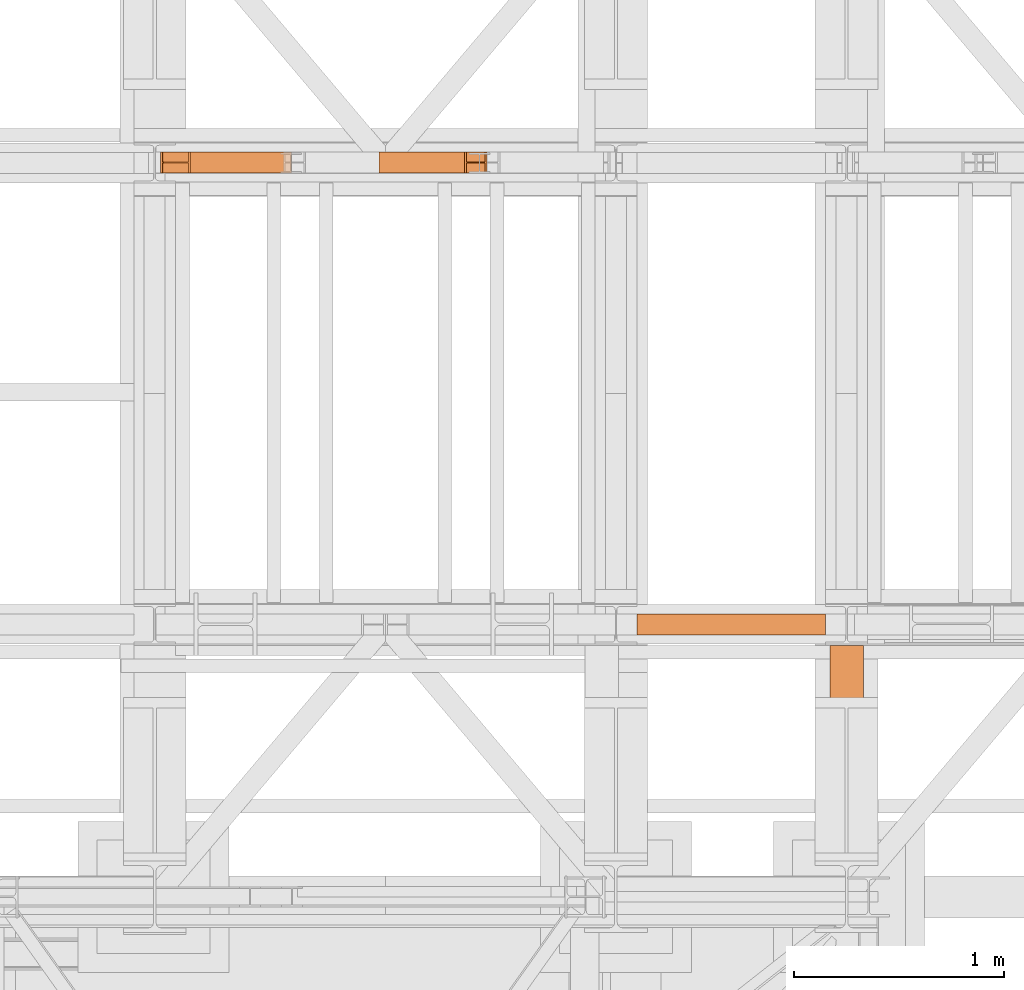
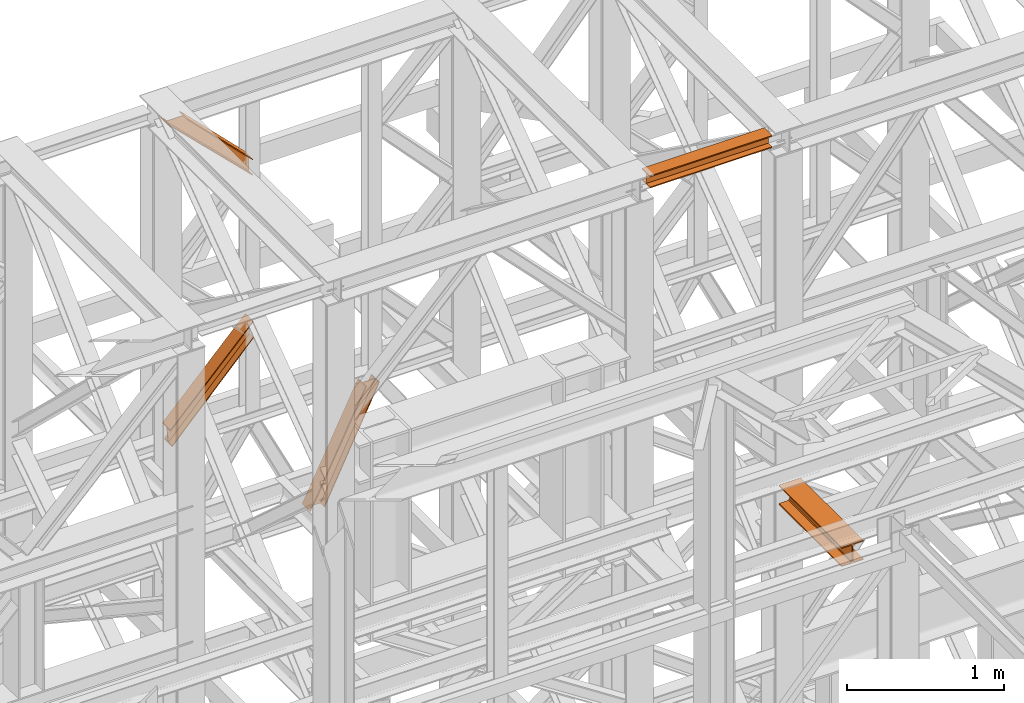
# One storey, part 204 of 208: 5 proxies.
"""IFC2X3 building model written with IfcOpenShell, lengths in millimetres."""

import ifcopenshell
import ifcopenshell.guid

model = None  # the IFC model being written
_history = None  # IfcOwnerHistory: only IFC2X3 demands one
_inside = {}  # id of a spatial element -> (the spatial element, [elements in it])
_under = {}  # id of a project, library or spatial element -> (it, [spatial elements below it])
_declared = {}  # id of a project -> (the project, [libraries it declares])
_typed = {}  # id of a type object -> (the type object, [elements of that type])
_made_of = {}  # id of a material, layer set ... -> (it, [elements and type objects made of it])


def new_model(schema):
    """Start an empty IFC model of exactly this schema.

    Asked for "IFC4X3", IfcOpenShell would pick the latest addendum, in which some entities
    have other attributes; the version numbers below select the first issue.
    IFC2X3 requires an IfcOwnerHistory on every rooted entity: one is made here for all.
    """
    global model, _history
    if schema == "IFC4X3":
        model = ifcopenshell.file(schema_version=(4, 3, 0, 0))
    else:
        model = ifcopenshell.file(schema=schema)
    _inside.clear()
    _under.clear()
    _declared.clear()
    _typed.clear()
    _made_of.clear()
    _history = None
    if model.schema == "IFC2X3":
        org = make("IfcOrganization", Name="unknown")
        user = make(
            "IfcPersonAndOrganization",
            ThePerson=make("IfcPerson", FamilyName="unknown"),
            TheOrganization=org,
        )
        app = make(
            "IfcApplication",
            ApplicationDeveloper=org,
            Version="unknown",
            ApplicationFullName="unknown",
            ApplicationIdentifier="unknown",
        )
        _history = make(
            "IfcOwnerHistory",
            OwningUser=user,
            OwningApplication=app,
            ChangeAction="ADDED",
            CreationDate=0,
        )
    return model


def make(cls, **values):
    """One entity of the class cls with the attributes given. An attribute that is None is left unset."""
    return model.create_entity(
        cls, **{name: value for name, value in values.items() if value is not None}
    )


def entity(cls, *values):
    """Any entity or typed value of the class cls, its attributes in the order of the schema. None: left unset."""
    e = model.create_entity(cls)
    for i, value in enumerate(values):
        if value is not None:
            e[i] = value
    return e


def rooted(cls, **values):
    """An entity with a GlobalId (a new one), such as an element, a storey or a relation."""
    return make(cls, GlobalId=ifcopenshell.guid.new(), OwnerHistory=_history, **values)


def si_unit(unit_type, name, prefix=None):
    """IfcSIUnit, for example si_unit("LENGTHUNIT", "METRE", prefix="MILLI")."""
    return make("IfcSIUnit", UnitType=unit_type, Prefix=prefix, Name=name)


def converted_unit(unit_type, name, factor, base, dimensions=None, offset=None):
    """IfcConversionBasedUnit, such as the inch: factor (a typed value) times the base unit."""
    return make(
        "IfcConversionBasedUnit"
        if offset is None
        else "IfcConversionBasedUnitWithOffset",
        ConversionOffset=offset,
        Dimensions=None
        if dimensions is None
        else entity("IfcDimensionalExponents", *dimensions),
        UnitType=unit_type,
        Name=name,
        ConversionFactor=make(
            "IfcMeasureWithUnit", ValueComponent=factor, UnitComponent=base
        ),
    )


def assignment(units):
    """IfcUnitAssignment: the units of a project."""
    return None if units is None else make("IfcUnitAssignment", Units=units)


def point(xyz):
    """IfcCartesianPoint."""
    return None if xyz is None else make("IfcCartesianPoint", Coordinates=xyz)


def direction(xyz):
    """IfcDirection."""
    return None if xyz is None else make("IfcDirection", DirectionRatios=xyz)


def frame(location, z_axis=None, x_axis=None):
    """IfcAxis2Placement3D, a coordinate frame: its origin and axes. An axis left out is left unset."""
    return make(
        "IfcAxis2Placement3D",
        Location=point(location),
        Axis=direction(z_axis),
        RefDirection=direction(x_axis),
    )


def origin():
    """The frame at (0, 0, 0) with its axes left unset."""
    return frame((0.0, 0.0, 0.0))


def origin_with_axes():
    """The frame at (0, 0, 0) with the z axis (0, 0, 1) and the x axis (1, 0, 0) written out."""
    return frame((0.0, 0.0, 0.0), z_axis=(0.0, 0.0, 1.0), x_axis=(1.0, 0.0, 0.0))


def place(relative_to, where):
    """IfcLocalPlacement: puts the frame where relative to a parent placement (None: the world)."""
    return make(
        "IfcLocalPlacement", PlacementRelTo=relative_to, RelativePlacement=where
    )


def context(
    kind, dimensions, precision=None, world=None, true_north=None, identifier=None
):
    """IfcGeometricRepresentationContext, for example the 3D "Model" context."""
    return make(
        "IfcGeometricRepresentationContext",
        ContextIdentifier=identifier,
        ContextType=kind,
        CoordinateSpaceDimension=dimensions,
        Precision=precision,
        WorldCoordinateSystem=world,
        TrueNorth=true_north,
    )


def subcontext(parent, identifier, kind, view, scale=None):
    """IfcGeometricRepresentationSubContext, for example "Body" below "Model"."""
    return make(
        "IfcGeometricRepresentationSubContext",
        ContextIdentifier=identifier,
        ContextType=kind,
        ParentContext=parent,
        TargetScale=scale,
        TargetView=view,
    )


def project(units=None, contexts=None):
    """IfcProject with its units and contexts."""
    return rooted(
        "IfcProject",
        Name="project",
        RepresentationContexts=contexts,
        UnitsInContext=assignment(units),
    )


def spatial(cls, under=None, at=None, **own):
    """A site, building, storey or space (cls), placed at a placement, below another one or the project."""
    s = rooted(cls, ObjectPlacement=at, **own)
    if under is not None:
        _under.setdefault(under.id(), (under, []))[1].append(s)
    return s


def faces_of(points, faces, orient=None, outer=None):
    """IfcFace entities. A face is a list of loops; a loop is a list of indices into points, from 0.

    orient and outer hold one flag for each loop. By default every Orientation is true, the
    first loop of a face is its IfcFaceOuterBound and the others are IfcFaceBound.
    """
    made = []
    for i, loops in enumerate(faces):
        bounds = []
        for j, loop in enumerate(loops):
            is_outer = j == 0 if outer is None else outer[i][j]
            bounds.append(
                make(
                    "IfcFaceOuterBound" if is_outer else "IfcFaceBound",
                    Bound=make("IfcPolyLoop", Polygon=[points[k] for k in loop]),
                    Orientation=True if orient is None else orient[i][j],
                )
            )
        made.append(make("IfcFace", Bounds=bounds))
    return made


def faceted_brep(points, faces, orient=None, outer=None, voids=None):
    """IfcFacetedBrep: a solid bounded by flat faces; with voids (closed shells), ...WithVoids."""
    shared = [point(p) for p in points]
    hull = make("IfcClosedShell", CfsFaces=faces_of(shared, faces, orient, outer))
    if voids is None:
        return make("IfcFacetedBrep", Outer=hull)
    return make(
        "IfcFacetedBrepWithVoids",
        Outer=hull,
        Voids=[
            make(cls, CfsFaces=faces_of(shared, fs, o, b)) for cls, fs, o, b in voids
        ],
    )


def shape(context_of_items, identifier, shape_type, items):
    """IfcShapeRepresentation: the items that make up one representation, for example the "Body"."""
    return make(
        "IfcShapeRepresentation",
        ContextOfItems=context_of_items,
        RepresentationIdentifier=identifier,
        RepresentationType=shape_type,
        Items=items,
    )


def made_of(thing, what):
    """Note that an element or type object is made of a material, layer set ...; save() writes the relation."""
    if what is not None:
        _made_of.setdefault(what.id(), (what, []))[1].append(thing)
    return thing


def element(
    cls,
    number,
    at=None,
    inside=None,
    cuts=None,
    type_object=None,
    material=None,
    context=None,
    identifier="Body",
    shape_type=None,
    held_by="IfcProductDefinitionShape",
    body=None,
    shapes=None,
    **own,
):
    """One element of the class cls, such as IfcWall. Its Tag is "e" and its number.

    at: its placement. inside: the storey or other place that contains it. cuts: it is an
    opening in that element (IfcRelVoidsElement). A single representation is given by context,
    identifier, shape_type and body (its items); several are given by shapes. held_by: the class
    of the entity that holds the representations. save() writes the other relations.
    """
    e = rooted(cls, Tag="e%d" % number, ObjectPlacement=at, **own)
    if body is not None:
        shapes = [shape(context, identifier, shape_type, body)]
    if shapes is not None:
        e.Representation = make(held_by, Representations=shapes)
    if inside is not None:
        _inside.setdefault(inside.id(), (inside, []))[1].append(e)
    if cuts is not None:
        rooted(
            "IfcRelVoidsElement", RelatingBuildingElement=cuts, RelatedOpeningElement=e
        )
    if type_object is not None:
        _typed.setdefault(type_object.id(), (type_object, []))[1].append(e)
    return made_of(e, material)


def aggregate(whole, parts):
    """IfcRelAggregates: a whole, such as a stair, and the parts it consists of."""
    return rooted("IfcRelAggregates", RelatingObject=whole, RelatedObjects=parts)


def save(model, path):
    """Write the relations noted so far, then the file.

    IfcRelAggregates (storeys below a building ...), IfcRelContainedInSpatialStructure (elements
    in a storey), IfcRelDefinesByType, IfcRelAssociatesMaterial and IfcRelDeclares: one each for
    every whole, place, type object, material and project.
    """
    for whole, parts in _under.values():
        aggregate(whole, parts)
    for where, things in _inside.values():
        rooted(
            "IfcRelContainedInSpatialStructure",
            RelatedElements=things,
            RelatingStructure=where,
        )
    for kind, things in _typed.values():
        rooted("IfcRelDefinesByType", RelatedObjects=things, RelatingType=kind)
    for what, things in _made_of.values():
        rooted("IfcRelAssociatesMaterial", RelatedObjects=things, RelatingMaterial=what)
    for by, libraries in _declared.values():
        rooted("IfcRelDeclares", RelatingContext=by, RelatedDefinitions=libraries)
    model.write(path)


model = new_model("IFC2X3")

# Units and contexts
model_context = context("Model", 3, precision=1e-05, world=origin())
plan_context = context("Plan", 3, precision=1e-05, world=origin())
body_context = subcontext(model_context, "Body", "Model", "MODEL_VIEW")
ifc_project = project(units=[si_unit("LENGTHUNIT", "METRE", prefix="MILLI"), converted_unit("PLANEANGLEUNIT", "DEGREE", entity("IfcPlaneAngleMeasure", 0.0174532925199433), si_unit("PLANEANGLEUNIT", "RADIAN"), dimensions=[0, 0, 0, 0, 0, 0, 0]), si_unit("AREAUNIT", "SQUARE_METRE"), si_unit("VOLUMEUNIT", "CUBIC_METRE")], contexts=[model_context, plan_context])

# Building, storey
building_placement = place(None, origin())
building = spatial("IfcBuilding", under=ifc_project, at=building_placement, CompositionType="COMPLEX")
storey_placement = place(building_placement, origin_with_axes())
storey = spatial("IfcBuildingStorey", under=building, at=storey_placement, Name="Geschoss", CompositionType="ELEMENT")

# Proxies
proxy_1_placement = place(storey_placement, frame((3335.574549118421, -13810.57439404318, 9738.383764068489), z_axis=(0.0, 0.0, 1.0), x_axis=(1.0, 0.0, 0.0)))
element("IfcBuildingElementProxy", 1, at=proxy_1_placement, inside=storey, context=body_context, shape_type="Brep", body=[
    faceted_brep([(0.8614801804683339, 0.01000000000021828, 127.1336120970282), (0.009999999999763531, 0.01000000000021828, 135.4554138886069), (610.1904194102467, 0.01000000000021828, 772.1793707618835), (610.1904194102467, 0.01000000000021828, 762.0805165043985), (0.009999999999763531, 0.01000000000021828, 135.4554138886069), (0.009999999999763531, 100.0100000000002, 135.4554138886069), (610.1904194102453, 100.0100000000002, 772.1793707618799), (610.1904194102467, 0.01000000000021828, 772.1793707618835), (0.009999999999763531, 100.0100000000002, 135.4554138886069), (0.8614801804683339, 100.0100000000002, 127.1336120970282), (610.1904194102467, 100.0100000000002, 762.0805165043985), (610.1904194102453, 100.0100000000002, 772.1793707618799), (0.8614801804683339, 100.0100000000002, 127.1336120970282), (0.8614801804683339, 52.51000000000022, 127.1336120970282), (610.1904194102467, 52.51000000000022, 762.0805165043985), (610.1904194102467, 100.0100000000002, 762.0805165043985), (0.8614801804683339, 52.51000000000022, 127.1336120970282), (13.01734256452937, 52.51000000000022, 8.330286210673876), (610.1904194102467, 52.51000000000022, 645.5811508176976), (610.1904194102467, 52.51000000000022, 762.0805165043985), (13.01734256452937, 52.51000000000022, 8.330286210673876), (13.01734256452937, 100.0100000000002, 8.330286210677514), (610.190419410249, 100.0100000000002, 645.5811508177048), (610.1904194102467, 52.51000000000022, 645.5811508176976), (13.01734256452937, 100.0100000000002, 8.330286210677514), (13.8686676719567, 100.0100000000002, 0.01000000000021828), (610.1904194102467, 100.0100000000002, 635.4780302121417), (610.190419410249, 100.0100000000002, 645.5811508177048), (13.8686676719567, 100.0100000000002, 0.01000000000021828), (13.86866767195761, 0.01000000000021828, 0.01000000000021828), (610.1904194102458, 0.01000000000021828, 635.4780302121417), (610.1904194102467, 100.0100000000002, 635.4780302121417), (13.86866767195761, 0.01000000000021828, 0.01000000000021828), (13.01734256452937, 0.01000000000021828, 8.330286210677514), (610.1904194102467, 0.01000000000021828, 645.5811508177048), (610.1904194102458, 0.01000000000021828, 635.4780302121417), (13.01734256452937, 0.01000000000021828, 8.330286210677514), (13.01734256452846, 47.51000000000022, 8.330286210681152), (610.1904194102462, 47.51000000000022, 645.5811508177048), (610.1904194102467, 0.01000000000021828, 645.5811508177048), (13.01734256452846, 47.51000000000022, 8.330286210681152), (0.8614801804683339, 47.51000000000022, 127.1336120970282), (610.1904194102467, 47.51000000000022, 762.0805165043985), (610.1904194102462, 47.51000000000022, 645.5811508177048), (0.8614801804683339, 47.51000000000022, 127.1336120970282), (0.8614801804683339, 0.01000000000021828, 127.1336120970282), (610.1904194102467, 0.01000000000021828, 762.0805165043985), (610.1904194102467, 47.51000000000022, 762.0805165043985), (0.009999999999763531, 0.01000000000021828, 135.4554138886069), (0.8614801804683339, 0.01000000000021828, 127.1336120970282), (0.8614801804683339, 47.51000000000022, 127.1336120970282), (13.01734256452846, 47.51000000000022, 8.330286210681152), (13.01734256452937, 0.01000000000021828, 8.330286210677514), (13.86866767195761, 0.01000000000021828, 0.01000000000021828), (13.8686676719567, 100.0100000000002, 0.01000000000021828), (13.01734256452937, 100.0100000000002, 8.330286210677514), (13.01734256452937, 52.51000000000022, 8.330286210673876), (0.8614801804683339, 52.51000000000022, 127.1336120970282), (0.8614801804683339, 100.0100000000002, 127.1336120970282), (0.009999999999763531, 100.0100000000002, 135.4554138886069), (610.1904194102467, 0.01000000000021828, 762.0805165043985), (610.1904194102467, 0.01000000000021828, 772.1793707618835), (610.1904194102453, 100.0100000000002, 772.1793707618799), (610.1904194102467, 100.0100000000002, 762.0805165043985), (610.1904194102467, 52.51000000000022, 762.0805165043985), (610.1904194102467, 52.51000000000022, 645.5811508176976), (610.190419410249, 100.0100000000002, 645.5811508177048), (610.1904194102467, 100.0100000000002, 635.4780302121417), (610.1904194102458, 0.01000000000021828, 635.4780302121417), (610.1904194102467, 0.01000000000021828, 645.5811508177048), (610.1904194102462, 47.51000000000022, 645.5811508177048), (610.1904194102467, 47.51000000000022, 762.0805165043985)], [[[0, 1, 2, 3]], [[4, 5, 6, 7]], [[8, 9, 10, 11]], [[12, 13, 14, 15]], [[16, 17, 18, 19]], [[20, 21, 22, 23]], [[24, 25, 26, 27]], [[28, 29, 30, 31]], [[32, 33, 34, 35]], [[36, 37, 38, 39]], [[40, 41, 42, 43]], [[44, 45, 46, 47]], [[48, 49, 50, 51, 52, 53, 54, 55, 56, 57, 58, 59]], [[60, 61, 62, 63, 64, 65, 66, 67, 68, 69, 70, 71]]], orient=[[False], [False], [False], [False], [False], [False], [False], [False], [False], [False], [False], [False], [False], [False]]),
])
proxy_2_placement = place(storey_placement, frame((3321.102838478852, -13810.57439404318, 11640.28097264272), z_axis=(0.0, 0.0, 1.0), x_axis=(1.0, 0.0, 0.0)))
element("IfcBuildingElementProxy", 2, at=proxy_2_placement, inside=storey, context=body_context, shape_type="Brep", body=[
    faceted_brep([(134.4022503379219, 0.01000000000203727, 609.7190860510873), (143.6237680844633, 0.01000000000021828, 609.7190860510873), (622.1621300498164, 0.01000000000021828, 130.8127730178949), (622.1621300498164, 0.01000000000021828, 120.9016769489845), (143.6237680844633, 0.01000000000021828, 609.7190860510873), (143.6237680844643, 100.0100000000002, 609.7190860510873), (622.1621300498127, 100.0100000000002, 130.8127730179022), (622.1621300498164, 0.01000000000021828, 130.8127730178949), (143.6237680844643, 100.0100000000002, 609.7190860510873), (134.4022503379219, 100.0100000000002, 609.7190860510873), (622.1621300498164, 100.0100000000002, 120.9016769489845), (622.1621300498127, 100.0100000000002, 130.8127730179022), (134.4022503379219, 100.0100000000002, 609.7190860510873), (134.402250337921, 52.51000000000022, 609.7190860510873), (622.1621300498168, 52.51000000000022, 120.9016769489808), (622.1621300498164, 100.0100000000002, 120.9016769489845), (134.402250337921, 52.51000000000022, 609.7190860510873), (9.2316220054945, 52.51000000000022, 609.7190860510873), (622.1621300498164, 52.51000000000022, 9.871029833511784), (622.1621300498168, 52.51000000000022, 120.9016769489808), (9.2316220054945, 52.51000000000022, 609.7190860510873), (9.231622005494955, 100.0100000000002, 609.7190860510909), (622.1621300498164, 100.0100000000002, 9.871029833511784), (622.1621300498164, 52.51000000000022, 9.871029833511784), (9.231622005494955, 100.0100000000002, 609.7190860510909), (0.009999999999763531, 100.0100000000002, 609.7190860510909), (622.1621300498164, 100.0100000000002, 0.01000000000021828), (622.1621300498164, 100.0100000000002, 9.871029833511784), (0.009999999999763531, 100.0100000000002, 609.7190860510909), (0.01000000000476575, 0.01000000000021828, 609.7190860510837), (622.1621300498164, 0.01000000000021828, 0.01000000000021828), (622.1621300498164, 100.0100000000002, 0.01000000000021828), (0.01000000000476575, 0.01000000000021828, 609.7190860510837), (9.231622005500867, 0.01000000000203727, 609.7190860510873), (622.1621300498164, 0.01000000000021828, 9.871029833511784), (622.1621300498164, 0.01000000000021828, 0.01000000000021828), (9.231622005500867, 0.01000000000203727, 609.7190860510873), (9.231622005498139, 47.51000000000022, 609.7190860510909), (622.1621300498164, 47.51000000000022, 9.871029833511784), (622.1621300498164, 0.01000000000021828, 9.871029833511784), (9.231622005498139, 47.51000000000022, 609.7190860510909), (134.4022503379219, 47.51000000000022, 609.7190860510873), (622.1621300498164, 47.51000000000022, 120.9016769489845), (622.1621300498164, 47.51000000000022, 9.871029833511784), (134.4022503379219, 47.51000000000022, 609.7190860510873), (134.4022503379219, 0.01000000000203727, 609.7190860510873), (622.1621300498164, 0.01000000000021828, 120.9016769489845), (622.1621300498164, 47.51000000000022, 120.9016769489845), (622.1621300498164, 0.01000000000021828, 120.9016769489845), (622.1621300498164, 0.01000000000021828, 130.8127730178949), (622.1621300498127, 100.0100000000002, 130.8127730179022), (622.1621300498164, 100.0100000000002, 120.9016769489845), (622.1621300498168, 52.51000000000022, 120.9016769489808), (622.1621300498164, 52.51000000000022, 9.871029833511784), (622.1621300498164, 100.0100000000002, 9.871029833511784), (622.1621300498164, 100.0100000000002, 0.01000000000021828), (622.1621300498164, 0.01000000000021828, 0.01000000000021828), (622.1621300498164, 0.01000000000021828, 9.871029833511784), (622.1621300498164, 47.51000000000022, 9.871029833511784), (622.1621300498164, 47.51000000000022, 120.9016769489845), (143.6237680844633, 0.01000000000021828, 609.7190860510873), (134.4022503379219, 0.01000000000203727, 609.7190860510873), (134.4022503379219, 47.51000000000022, 609.7190860510873), (9.231622005498139, 47.51000000000022, 609.7190860510909), (9.231622005500867, 0.01000000000203727, 609.7190860510873), (0.01000000000476575, 0.01000000000021828, 609.7190860510837), (0.009999999999763531, 100.0100000000002, 609.7190860510909), (9.231622005494955, 100.0100000000002, 609.7190860510909), (9.2316220054945, 52.51000000000022, 609.7190860510873), (134.402250337921, 52.51000000000022, 609.7190860510873), (134.4022503379219, 100.0100000000002, 609.7190860510873), (143.6237680844643, 100.0100000000002, 609.7190860510873)], [[[0, 1, 2, 3]], [[4, 5, 6, 7]], [[8, 9, 10, 11]], [[12, 13, 14, 15]], [[16, 17, 18, 19]], [[20, 21, 22, 23]], [[24, 25, 26, 27]], [[28, 29, 30, 31]], [[32, 33, 34, 35]], [[36, 37, 38, 39]], [[40, 41, 42, 43]], [[44, 45, 46, 47]], [[48, 49, 50, 51, 52, 53, 54, 55, 56, 57, 58, 59]], [[60, 61, 62, 63, 64, 65, 66, 67, 68, 69, 70, 71]]], orient=[[False], [False], [False], [False], [False], [False], [False], [False], [False], [False], [False], [False], [False], [False]]),
])
proxy_3_placement = place(storey_placement, frame((4361.963058466044, -13810.57439404318, 8881.007354628784), z_axis=(0.0, 0.0, 1.0), x_axis=(1.0, 0.0, 0.0)))
element("IfcBuildingElementProxy", 3, at=proxy_3_placement, inside=storey, context=body_context, shape_type="Brep", body=[
    faceted_brep([(0.01000000000021828, 0.01000000000021828, 0.01000000000021828), (409.9553058525798, 0.01000000000021828, 829.1083585935612), (417.6513064777428, 0.01000000000021828, 829.1083585935612), (7.199069198474717, 0.01000000000021828, 0.01000000000021828), (0.01000000000112777, 100.0100000000002, 0.01000000000021828), (409.9553058525835, 100.0100000000002, 829.1083585935612), (409.9553058525798, 0.01000000000021828, 829.1083585935612), (0.01000000000021828, 0.01000000000021828, 0.01000000000021828), (7.199069198474717, 100.0100000000002, 0.01000000000021828), (417.6513064777428, 100.0100000000002, 829.1083585935612), (409.9553058525835, 100.0100000000002, 829.1083585935612), (0.01000000000112777, 100.0100000000002, 0.01000000000021828), (7.199069198474717, 52.51000000000022, 0.01000000000385626), (417.6513064777428, 52.51000000000022, 829.1083585935612), (417.6513064777428, 100.0100000000002, 829.1083585935612), (7.199069198474717, 100.0100000000002, 0.01000000000021828), (105.6645407648803, 52.51000000000022, 0.01000000000021828), (507.4580362298721, 52.51000000000022, 829.1083585935612), (417.6513064777428, 52.51000000000022, 829.1083585935612), (7.199069198474717, 52.51000000000022, 0.01000000000385626), (105.6645407648784, 100.0100000000002, 0.01000000000021828), (507.4580362298684, 100.0100000000002, 829.1083585935612), (507.4580362298721, 52.51000000000022, 829.1083585935612), (105.6645407648803, 52.51000000000022, 0.01000000000021828), (112.8453822667971, 100.0100000000002, 0.01000000000021828), (515.1363869069501, 100.0100000000002, 829.1083585935612), (507.4580362298684, 100.0100000000002, 829.1083585935612), (105.6645407648784, 100.0100000000002, 0.01000000000021828), (112.8453822667971, 0.01000000000021828, 0.01000000000021828), (515.1363869069501, 0.01000000000021828, 829.1083585935612), (515.1363869069501, 100.0100000000002, 829.1083585935612), (112.8453822667971, 100.0100000000002, 0.01000000000021828), (105.6645407648784, 0.01000000000021828, 0.01000000000021828), (507.4580362298666, 0.01000000000021828, 829.1083585935612), (515.1363869069501, 0.01000000000021828, 829.1083585935612), (112.8453822667971, 0.01000000000021828, 0.01000000000021828), (105.6645407648766, 47.51000000000022, 0.01000000000021828), (507.4580362298666, 47.51000000000022, 829.1083585935612), (507.4580362298666, 0.01000000000021828, 829.1083585935612), (105.6645407648784, 0.01000000000021828, 0.01000000000021828), (7.199069198474717, 47.51000000000022, 0.01000000000385626), (417.6513064777428, 47.51000000000022, 829.1083585935612), (507.4580362298666, 47.51000000000022, 829.1083585935612), (105.6645407648766, 47.51000000000022, 0.01000000000021828), (7.199069198474717, 0.01000000000021828, 0.01000000000021828), (417.6513064777428, 0.01000000000021828, 829.1083585935612), (417.6513064777428, 47.51000000000022, 829.1083585935612), (7.199069198474717, 47.51000000000022, 0.01000000000385626), (409.9553058525798, 0.01000000000021828, 829.1083585935612), (409.9553058525835, 100.0100000000002, 829.1083585935612), (417.6513064777428, 100.0100000000002, 829.1083585935612), (417.6513064777428, 52.51000000000022, 829.1083585935612), (507.4580362298721, 52.51000000000022, 829.1083585935612), (507.4580362298684, 100.0100000000002, 829.1083585935612), (515.1363869069501, 100.0100000000002, 829.1083585935612), (515.1363869069501, 0.01000000000021828, 829.1083585935612), (507.4580362298666, 0.01000000000021828, 829.1083585935612), (507.4580362298666, 47.51000000000022, 829.1083585935612), (417.6513064777428, 47.51000000000022, 829.1083585935612), (417.6513064777428, 0.01000000000021828, 829.1083585935612), (7.199069198474717, 0.01000000000021828, 0.01000000000021828), (7.199069198474717, 47.51000000000022, 0.01000000000385626), (105.6645407648766, 47.51000000000022, 0.01000000000021828), (105.6645407648784, 0.01000000000021828, 0.01000000000021828), (112.8453822667971, 0.01000000000021828, 0.01000000000021828), (112.8453822667971, 100.0100000000002, 0.01000000000021828), (105.6645407648784, 100.0100000000002, 0.01000000000021828), (105.6645407648803, 52.51000000000022, 0.01000000000021828), (7.199069198474717, 52.51000000000022, 0.01000000000385626), (7.199069198474717, 100.0100000000002, 0.01000000000021828), (0.01000000000112777, 100.0100000000002, 0.01000000000021828), (0.01000000000021828, 0.01000000000021828, 0.01000000000021828)], [[[0, 1, 2, 3]], [[4, 5, 6, 7]], [[8, 9, 10, 11]], [[12, 13, 14, 15]], [[16, 17, 18, 19]], [[20, 21, 22, 23]], [[24, 25, 26, 27]], [[28, 29, 30, 31]], [[32, 33, 34, 35]], [[36, 37, 38, 39]], [[40, 41, 42, 43]], [[44, 45, 46, 47]], [[48, 49, 50, 51, 52, 53, 54, 55, 56, 57, 58, 59]], [[60, 61, 62, 63, 64, 65, 66, 67, 68, 69, 70, 71]]], orient=[[False], [False], [False], [False], [False], [False], [False], [False], [False], [False], [False], [False], [False], [False]]),
])
proxy_4_placement = place(storey_placement, frame((5593.254970018782, -16012.50587051043, 12300.47045114381), z_axis=(0.0, 0.0, 1.0), x_axis=(1.0, 0.0, 0.0)))
element("IfcBuildingElementProxy", 4, at=proxy_4_placement, inside=storey, context=body_context, shape_type="Brep", body=[
    faceted_brep([(900.009997019768, 0.01000000000021828, 88.01000000000022), (900.009997019768, 0.01000000000021828, 96.01000000000022), (900.009997019768, 100.0100000000002, 96.01000000000022), (900.009997019768, 100.0100000000002, 88.01000000000022), (900.009997019768, 52.51000000000022, 88.01000000000022), (900.009997019768, 52.51000000000022, 8.010000000000218), (900.009997019768, 100.0100000000002, 8.010000000000218), (900.009997019768, 100.0100000000002, 0.01000000000021828), (900.009997019768, 0.01000000000021828, 0.01000000000021828), (900.009997019768, 0.01000000000021828, 8.010000000000218), (900.009997019768, 47.51000000000022, 8.010000000000218), (900.009997019768, 47.51000000000022, 88.01000000000022), (900.009997019768, 0.01000000000021828, 96.01000000000022), (900.009997019768, 0.01000000000021828, 88.01000000000022), (0.01000000000021828, 0.01000000000385626, 88.01000000000022), (0.01000000000021828, 0.01000000000385626, 96.01000000000022), (900.009997019768, 100.0100000000002, 96.01000000000022), (900.009997019768, 0.01000000000021828, 96.01000000000022), (0.01000000000021828, 0.01000000000385626, 96.01000000000022), (0.01000000000021828, 100.0100000000039, 96.01000000000022), (900.009997019768, 100.0100000000002, 88.01000000000022), (900.009997019768, 100.0100000000002, 96.01000000000022), (0.01000000000021828, 100.0100000000039, 96.01000000000022), (0.01000000000021828, 100.0100000000039, 88.01000000000022), (900.009997019768, 52.51000000000022, 88.01000000000022), (900.009997019768, 100.0100000000002, 88.01000000000022), (0.01000000000021828, 100.0100000000039, 88.01000000000022), (0.01000000000021828, 52.51000000000386, 88.01000000000022), (900.009997019768, 52.51000000000022, 8.010000000000218), (900.009997019768, 52.51000000000022, 88.01000000000022), (0.01000000000021828, 52.51000000000386, 88.01000000000022), (0.01000000000021828, 52.51000000000386, 8.010000000000218), (900.009997019768, 100.0100000000002, 8.010000000000218), (900.009997019768, 52.51000000000022, 8.010000000000218), (0.01000000000021828, 52.51000000000386, 8.010000000000218), (0.01000000000021828, 100.0100000000039, 8.010000000000218), (900.009997019768, 100.0100000000002, 0.01000000000021828), (900.009997019768, 100.0100000000002, 8.010000000000218), (0.01000000000021828, 100.0100000000039, 8.010000000000218), (0.01000000000021828, 100.0100000000039, 0.01000000000021828), (900.009997019768, 0.01000000000021828, 0.01000000000021828), (900.009997019768, 100.0100000000002, 0.01000000000021828), (0.01000000000021828, 100.0100000000039, 0.01000000000021828), (0.01000000000021828, 0.01000000000385626, 0.01000000000021828), (900.009997019768, 0.01000000000021828, 8.010000000000218), (900.009997019768, 0.01000000000021828, 0.01000000000021828), (0.01000000000021828, 0.01000000000385626, 0.01000000000021828), (0.01000000000021828, 0.01000000000385626, 8.010000000000218), (900.009997019768, 47.51000000000022, 8.010000000000218), (900.009997019768, 0.01000000000021828, 8.010000000000218), (0.01000000000021828, 0.01000000000385626, 8.010000000000218), (0.01000000000021828, 47.51000000000386, 8.010000000000218), (900.009997019768, 47.51000000000022, 88.01000000000022), (900.009997019768, 47.51000000000022, 8.010000000000218), (0.01000000000021828, 47.51000000000386, 8.010000000000218), (0.01000000000021828, 47.51000000000386, 88.01000000000022), (900.009997019768, 0.01000000000021828, 88.01000000000022), (900.009997019768, 47.51000000000022, 88.01000000000022), (0.01000000000021828, 47.51000000000386, 88.01000000000022), (0.01000000000021828, 0.01000000000385626, 88.01000000000022), (0.01000000000021828, 0.01000000000385626, 88.01000000000022), (0.01000000000021828, 47.51000000000386, 88.01000000000022), (0.01000000000021828, 47.51000000000386, 8.010000000000218), (0.01000000000021828, 0.01000000000385626, 8.010000000000218), (0.01000000000021828, 0.01000000000385626, 0.01000000000021828), (0.01000000000021828, 100.0100000000039, 0.01000000000021828), (0.01000000000021828, 100.0100000000039, 8.010000000000218), (0.01000000000021828, 52.51000000000386, 8.010000000000218), (0.01000000000021828, 52.51000000000386, 88.01000000000022), (0.01000000000021828, 100.0100000000039, 88.01000000000022), (0.01000000000021828, 100.0100000000039, 96.01000000000022), (0.01000000000021828, 0.01000000000385626, 96.01000000000022)], [[[0, 1, 2, 3, 4, 5, 6, 7, 8, 9, 10, 11]], [[12, 13, 14, 15]], [[16, 17, 18, 19]], [[20, 21, 22, 23]], [[24, 25, 26, 27]], [[28, 29, 30, 31]], [[32, 33, 34, 35]], [[36, 37, 38, 39]], [[40, 41, 42, 43]], [[44, 45, 46, 47]], [[48, 49, 50, 51]], [[52, 53, 54, 55]], [[56, 57, 58, 59]], [[60, 61, 62, 63, 64, 65, 66, 67, 68, 69, 70, 71]]], orient=[[False], [False], [False], [False], [False], [False], [False], [False], [False], [False], [False], [False], [False], [False]]),
])
proxy_5_placement = place(storey_placement, frame((6513.639277448148, -16862.57439180801, 9547.98998998642), z_axis=(0.0, 0.0, 1.0), x_axis=(1.0, 0.0, 0.0)))
element("IfcBuildingElementProxy", 5, at=proxy_5_placement, inside=storey, context=body_context, shape_type="Brep", body=[
    faceted_brep([(160.0100113248827, 0.00999999999839929, 0.01000000000021828), (0.01000000000021828, 0.00999999999839929, 0.01000000000021828), (0.01000000000021828, 0.00999999999839929, 9.010003337860326), (62.01000457465671, 0.00999999999839929, 9.010003337860326), (69.7731807997825, 0.00999999999839929, 10.5637921190264), (75.4562154582145, 0.00999999999839929, 16.24682677745841), (77.01000563636444, 0.00999999999839929, 24.01000020861648), (77.01000563636444, 0.00999999999839929, 128.010006079674), (75.4562154582145, 0.00999999999839929, 135.7731832361224), (69.7731807997825, 0.00999999999839929, 141.4562178945544), (62.01000457465671, 0.00999999999839929, 143.0100066757204), (0.01000000000021828, 0.00999999999839929, 143.0100066757204), (0.01000000000021828, 0.00999999999839929, 152.0100100135805), (160.0100113248827, 0.00999999999839929, 152.0100100135805), (160.0100113248827, 0.00999999999839929, 143.0100066757204), (98.01000675022624, 0.00999999999839929, 143.0100066757204), (90.24683052510045, 0.00999999999839929, 141.4562178945544), (84.56379586666844, 0.00999999999839929, 135.7731832361224), (83.0100056885185, 0.00999999999839929, 128.010006079674), (83.0100056885185, 0.00999999999839929, 24.01000020861648), (84.56379586666844, 0.00999999999839929, 16.24682677745841), (90.24683052510045, 0.00999999999839929, 10.5637921190264), (98.01000675022624, 0.00999999999839929, 9.010003337860326), (160.0100113248827, 0.00999999999839929, 9.010003337860326), (0.01000000000021828, 0.00999999999839929, 0.01000000000021828), (160.0100113248827, 0.00999999999839929, 0.01000000000021828), (160.0100113248791, 800.0100000000039, 0.01000000000021828), (0.01000000000021828, 800.0100000000039, 0.01000000000021828), (0.01000000000021828, 0.00999999999839929, 9.010003337860326), (0.01000000000021828, 0.00999999999839929, 0.01000000000021828), (0.01000000000021828, 800.0100000000039, 0.01000000000021828), (0.01000000000021828, 800.0100000000039, 9.010003337860326), (62.01000457465671, 0.00999999999839929, 9.010003337860326), (0.01000000000021828, 0.00999999999839929, 9.010003337860326), (0.01000000000021828, 800.0100000000039, 9.010003337860326), (62.01000457465671, 800.0100000000039, 9.010003337860326), (69.7731807997825, 0.00999999999839929, 10.5637921190264), (62.01000457465671, 0.00999999999839929, 9.010003337860326), (62.01000457465671, 800.0100000000039, 9.010003337860326), (69.77318079977886, 800.0100000000039, 10.5637921190264), (75.4562154582145, 0.00999999999839929, 16.24682677745841), (69.7731807997825, 0.00999999999839929, 10.5637921190264), (69.77318079977886, 800.0100000000039, 10.5637921190264), (75.45621545821086, 800.0100000000039, 16.24682677745841), (77.01000563636444, 0.00999999999839929, 24.01000020861648), (75.4562154582145, 0.00999999999839929, 16.24682677745841), (75.45621545821086, 800.0100000000039, 16.24682677745841), (77.0100056363608, 800.0100000000039, 24.01000020861648), (77.01000563636444, 0.00999999999839929, 128.010006079674), (77.01000563636444, 0.00999999999839929, 24.01000020861648), (77.0100056363608, 800.0100000000039, 24.01000020861648), (77.0100056363608, 800.0100000000039, 128.010006079674), (75.4562154582145, 0.00999999999839929, 135.7731832361224), (77.01000563636444, 0.00999999999839929, 128.010006079674), (77.0100056363608, 800.0100000000039, 128.010006079674), (75.45621545821086, 800.0100000000039, 135.7731832361224), (69.7731807997825, 0.00999999999839929, 141.4562178945544), (75.4562154582145, 0.00999999999839929, 135.7731832361224), (75.45621545821086, 800.0100000000039, 135.7731832361224), (69.77318079977886, 800.0100000000039, 141.4562178945544), (62.01000457465671, 0.00999999999839929, 143.0100066757204), (69.7731807997825, 0.00999999999839929, 141.4562178945544), (69.77318079977886, 800.0100000000039, 141.4562178945544), (62.01000457465307, 800.0100000000039, 143.0100066757204), (0.01000000000021828, 0.00999999999839929, 143.0100066757204), (62.01000457465671, 0.00999999999839929, 143.0100066757204), (62.01000457465307, 800.0100000000039, 143.0100066757204), (0.01000000000021828, 800.0100000000039, 143.0100066757204), (0.01000000000021828, 0.00999999999839929, 152.0100100135805), (0.01000000000021828, 0.00999999999839929, 143.0100066757204), (0.01000000000021828, 800.0100000000039, 143.0100066757204), (0.01000000000021828, 800.0100000000039, 152.0100100135805), (160.0100113248827, 0.00999999999839929, 152.0100100135805), (0.01000000000021828, 0.00999999999839929, 152.0100100135805), (0.01000000000021828, 800.0100000000039, 152.0100100135805), (160.0100113248827, 800.0100000000039, 152.0100100135842), (160.0100113248827, 0.00999999999839929, 143.0100066757204), (160.0100113248827, 0.00999999999839929, 152.0100100135805), (160.0100113248827, 800.0100000000039, 152.0100100135842), (160.0100113248827, 800.0100000000039, 143.0100066757204), (98.01000675022624, 0.00999999999839929, 143.0100066757204), (160.0100113248827, 0.00999999999839929, 143.0100066757204), (160.0100113248827, 800.0100000000039, 143.0100066757204), (98.0100067502226, 800.0100000000039, 143.0100066757204), (90.24683052510045, 0.00999999999839929, 141.4562178945544), (98.01000675022624, 0.00999999999839929, 143.0100066757204), (98.0100067502226, 800.0100000000039, 143.0100066757204), (90.24683052509681, 800.0100000000039, 141.4562178945544), (84.56379586666844, 0.00999999999839929, 135.7731832361224), (90.24683052510045, 0.00999999999839929, 141.4562178945544), (90.24683052509681, 800.0100000000039, 141.4562178945544), (84.5637958666648, 800.0100000000039, 135.773183236126), (83.0100056885185, 0.00999999999839929, 128.010006079674), (84.56379586666844, 0.00999999999839929, 135.7731832361224), (84.5637958666648, 800.0100000000039, 135.773183236126), (83.01000568851487, 800.0100000000039, 128.0100060796776), (83.0100056885185, 0.00999999999839929, 24.01000020861648), (83.0100056885185, 0.00999999999839929, 128.010006079674), (83.01000568851487, 800.0100000000039, 128.0100060796776), (83.01000568851487, 800.0100000000039, 24.01000020861648), (84.56379586666844, 0.00999999999839929, 16.24682677745841), (83.0100056885185, 0.00999999999839929, 24.01000020861648), (83.01000568851487, 800.0100000000039, 24.01000020861648), (84.5637958666648, 800.0100000000039, 16.24682677745841), (90.24683052510045, 0.00999999999839929, 10.5637921190264), (84.56379586666844, 0.00999999999839929, 16.24682677745841), (84.5637958666648, 800.0100000000039, 16.24682677745841), (90.24683052509681, 800.0100000000039, 10.5637921190264), (98.01000675022624, 0.00999999999839929, 9.010003337860326), (90.24683052510045, 0.00999999999839929, 10.5637921190264), (90.24683052509681, 800.0100000000039, 10.5637921190264), (98.0100067502226, 800.0100000000039, 9.010003337860326), (160.0100113248827, 0.00999999999839929, 9.010003337860326), (98.01000675022624, 0.00999999999839929, 9.010003337860326), (98.0100067502226, 800.0100000000039, 9.010003337860326), (160.0100113248827, 800.0100000000039, 9.010003337860326), (160.0100113248827, 0.00999999999839929, 0.01000000000021828), (160.0100113248827, 0.00999999999839929, 9.010003337860326), (160.0100113248827, 800.0100000000039, 9.010003337860326), (160.0100113248791, 800.0100000000039, 0.01000000000021828), (160.0100113248791, 800.0100000000039, 0.01000000000021828), (160.0100113248827, 800.0100000000039, 9.010003337860326), (98.0100067502226, 800.0100000000039, 9.010003337860326), (90.24683052509681, 800.0100000000039, 10.5637921190264), (84.5637958666648, 800.0100000000039, 16.24682677745841), (83.01000568851487, 800.0100000000039, 24.01000020861648), (83.01000568851487, 800.0100000000039, 128.0100060796776), (84.5637958666648, 800.0100000000039, 135.773183236126), (90.24683052509681, 800.0100000000039, 141.4562178945544), (98.0100067502226, 800.0100000000039, 143.0100066757204), (160.0100113248827, 800.0100000000039, 143.0100066757204), (160.0100113248827, 800.0100000000039, 152.0100100135842), (0.01000000000021828, 800.0100000000039, 152.0100100135805), (0.01000000000021828, 800.0100000000039, 143.0100066757204), (62.01000457465307, 800.0100000000039, 143.0100066757204), (69.77318079977886, 800.0100000000039, 141.4562178945544), (75.45621545821086, 800.0100000000039, 135.7731832361224), (77.0100056363608, 800.0100000000039, 128.010006079674), (77.0100056363608, 800.0100000000039, 24.01000020861648), (75.45621545821086, 800.0100000000039, 16.24682677745841), (69.77318079977886, 800.0100000000039, 10.5637921190264), (62.01000457465671, 800.0100000000039, 9.010003337860326), (0.01000000000021828, 800.0100000000039, 9.010003337860326), (0.01000000000021828, 800.0100000000039, 0.01000000000021828)], [[[0, 1, 2, 3, 4, 5, 6, 7, 8, 9, 10, 11, 12, 13, 14, 15, 16, 17, 18, 19, 20, 21, 22, 23]], [[24, 25, 26, 27]], [[28, 29, 30, 31]], [[32, 33, 34, 35]], [[36, 37, 38, 39]], [[40, 41, 42, 43]], [[44, 45, 46, 47]], [[48, 49, 50, 51]], [[52, 53, 54, 55]], [[56, 57, 58, 59]], [[60, 61, 62, 63]], [[64, 65, 66, 67]], [[68, 69, 70, 71]], [[72, 73, 74, 75]], [[76, 77, 78, 79]], [[80, 81, 82, 83]], [[84, 85, 86, 87]], [[88, 89, 90, 91]], [[92, 93, 94, 95]], [[96, 97, 98, 99]], [[100, 101, 102, 103]], [[104, 105, 106, 107]], [[108, 109, 110, 111]], [[112, 113, 114, 115]], [[116, 117, 118, 119]], [[120, 121, 122, 123, 124, 125, 126, 127, 128, 129, 130, 131, 132, 133, 134, 135, 136, 137, 138, 139, 140, 141, 142, 143]]], orient=[[False], [False], [False], [False], [False], [False], [False], [False], [False], [False], [False], [False], [False], [False], [False], [False], [False], [False], [False], [False], [False], [False], [False], [False], [False], [False]]),
])

save(model, "model.ifc")
